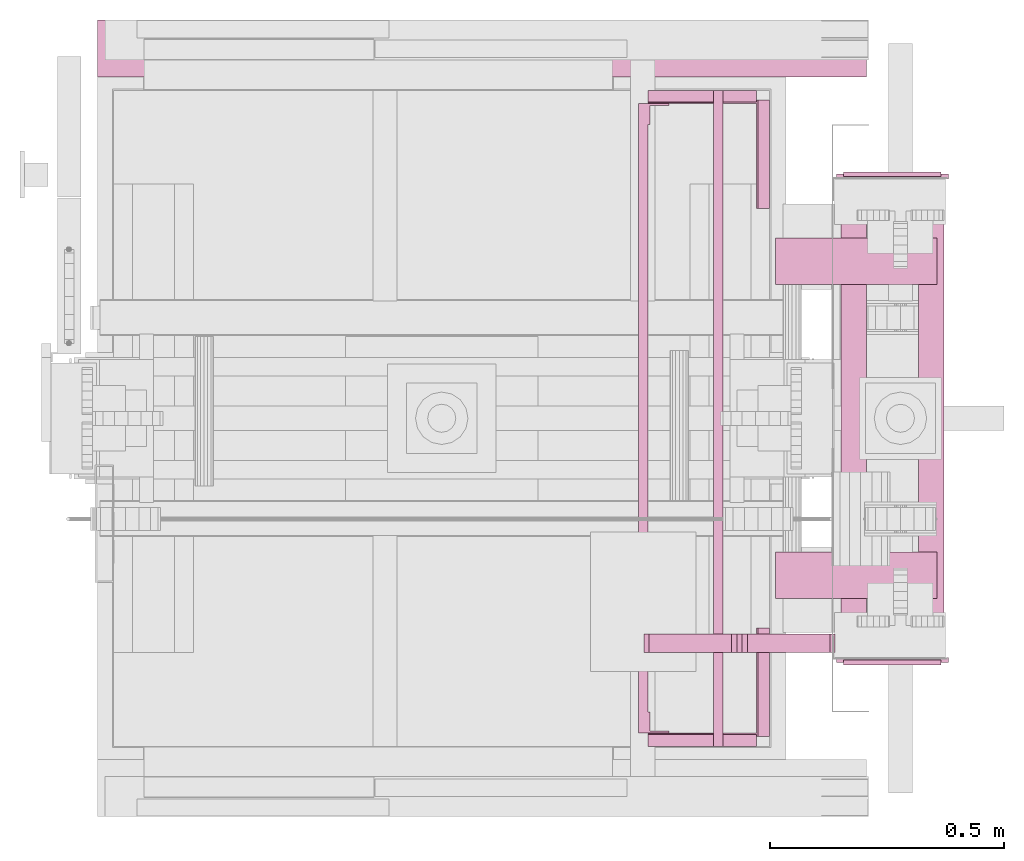
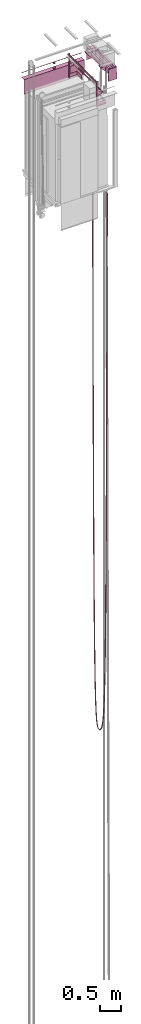
# One storey, part 6 of 13: 4 transport elements.
"""IFC4 building model written with IfcOpenShell, lengths in millimetres."""

from ifc_helpers import new_model, entity, si_unit, converted_unit, frame, origin_with_axes, place, context, subcontext, project, spatial, faceted_brep, element, save


model = new_model("IFC4")

# Units and contexts
context_of_model = context(None, 3, precision=0.01, world=origin_with_axes())
sub_context_1 = subcontext(context_of_model, None, None, "MODEL_VIEW")
sub_context_2 = subcontext(context_of_model, None, None, "MODEL_VIEW")
sub_context_3 = subcontext(context_of_model, None, None, "MODEL_VIEW")
sub_context_4 = subcontext(context_of_model, None, None, "MODEL_VIEW")
ifc_project = project(units=[converted_unit("PLANEANGLEUNIT", "degree", entity("IfcPlaneAngleMeasure", 0.017453292519943), si_unit("PLANEANGLEUNIT", "RADIAN"), dimensions=[0, 0, 0, 0, 0, 0, 0]), si_unit("LENGTHUNIT", "METRE", prefix="MILLI"), si_unit("MASSUNIT", "GRAM", prefix="KILO"), converted_unit("TIMEUNIT", "year", entity("IfcTimeMeasure", 31557600.0), si_unit("TIMEUNIT", "SECOND"), dimensions=[0, 0, 1, 0, 0, 0, 0]), si_unit("THERMODYNAMICTEMPERATUREUNIT", "DEGREE_CELSIUS"), si_unit("AREAUNIT", "SQUARE_METRE"), si_unit("FORCEUNIT", "NEWTON"), si_unit("VOLUMEUNIT", "CUBIC_METRE"), si_unit("PRESSUREUNIT", "PASCAL"), si_unit("SOLIDANGLEUNIT", "STERADIAN")], contexts=[context_of_model])

# Site, building, storey
site = spatial("IfcSite", under=ifc_project)
building = spatial("IfcBuilding", under=site, Name="Document")
placement = place(None, origin_with_axes())
storey_placement = place(placement, frame((0.0, 0.0, -26400.0), z_axis=(0.0, 0.0, 1.0), x_axis=(1.0, 0.0, 0.0)))
storey = spatial("IfcBuildingStorey", under=building, at=storey_placement, Name="Z -26400", Elevation=-26400.0)

# Transport elements
transport_element_1_placement = place(storey_placement, frame((200.0, 325.0, 33569.0), z_axis=(0.0, 0.0, 1.0), x_axis=(1.0, 0.0, 0.0)))
element("IfcTransportElement", 1, at=transport_element_1_placement, inside=storey, PredefinedType="ELEVATOR", context=sub_context_1, shape_type="Brep", body=[
    faceted_brep([(1140.0, 1372.0, 395.0), (1140.0, 1374.0, 395.0), (1140.0, 1374.0, 305.0), (1140.0, 1372.0, 305.0), (1280.0, 1372.0, 395.0), (1280.0, 1372.0, 305.0), (1280.0, 1374.0, 305.0), (1280.0, 1374.0, 395.0)], [[[0, 1, 2, 3]], [[4, 5, 6, 7]], [[0, 3, 5, 4]], [[3, 2, 6, 5]], [[2, 1, 7, 6]], [[1, 0, 4, 7]]]),
    faceted_brep([(1140.0, 1327.0, 700.0), (1140.0, 1372.0, 700.0), (1140.0, 1372.0, 0.0), (1140.0, 1327.0, 0.0), (1145.0, 1367.0, 0.0), (1145.0, 1367.0, 700.0), (1145.0, 1327.0, 700.0), (1145.0, 1327.0, 0.0), (1185.0, 1372.0, 0.0), (1185.0, 1372.0, 700.0), (1185.0, 1367.0, 700.0), (1185.0, 1367.0, 0.0)], [[[0, 1, 2, 3]], [[4, 5, 6, 7]], [[8, 9, 10, 11]], [[7, 6, 0, 3]], [[1, 9, 8, 2]], [[11, 10, 5, 4]], [[2, 8, 11, 4, 7, 3]], [[6, 5, 10, 9, 1, 0]]]),
    faceted_brep([(1140.0, 28.0, 700.0), (1140.0, 73.0, 700.0), (1140.0, 73.0, 0.0), (1140.0, 28.0, 0.0), (1145.0, 73.0, 0.0), (1145.0, 73.0, 700.0), (1145.0, 33.0, 700.0), (1145.0, 33.0, 0.0), (1185.0, 33.0, 0.0), (1185.0, 33.0, 700.0), (1185.0, 28.0, 700.0), (1185.0, 28.0, 0.0)], [[[0, 1, 2, 3]], [[4, 5, 6, 7]], [[8, 9, 10, 11]], [[11, 10, 0, 3]], [[6, 9, 8, 7]], [[1, 5, 4, 2]], [[3, 2, 4, 7, 8, 11]], [[10, 9, 6, 5, 1, 0]]]),
    faceted_brep([(1372.0, 1147.25, 101.0), (1372.0, 1379.25, 101.0), (1372.0, 1379.25, 0.0), (1372.0, 1147.25, 0.0), (1375.0, 1379.25, 3.0), (1375.0, 1379.25, 101.0), (1375.0, 1147.25, 101.0), (1375.0, 1147.25, 3.0), (1400.0, 1379.25, 0.0), (1400.0, 1379.25, 3.0), (1400.0, 1147.25, 3.0), (1400.0, 1147.25, 0.0)], [[[0, 1, 2, 3]], [[4, 5, 6, 7]], [[8, 9, 10, 11]], [[3, 11, 10, 7, 6, 0]], [[1, 5, 4, 9, 8, 2]], [[2, 8, 11, 3]], [[10, 9, 4, 7]], [[6, 5, 1, 0]]]),
    faceted_brep([(1140.0, 26.0, 395.0), (1140.0, 28.0, 395.0), (1140.0, 28.0, 305.0), (1140.0, 26.0, 305.0), (1280.0, 26.0, 395.0), (1280.0, 26.0, 305.0), (1280.0, 28.0, 305.0), (1280.0, 28.0, 395.0)], [[[0, 1, 2, 3]], [[4, 5, 6, 7]], [[0, 3, 5, 4]], [[3, 2, 6, 5]], [[2, 1, 7, 6]], [[1, 0, 4, 7]]]),
    faceted_brep([(1280.0, 0.0, 370.0), (1280.0, 1400.0, 370.0), (1280.0, 1400.0, 330.0), (1280.0, 0.0, 330.0), (1283.0, 1400.0, 333.0), (1283.0, 1400.0, 367.0), (1283.0, 0.0, 367.0), (1283.0, 0.0, 333.0), (1300.0, 1400.0, 330.0), (1300.0, 1400.0, 333.0), (1300.0, 0.0, 333.0), (1300.0, 0.0, 330.0), (1300.0, 1400.0, 367.0), (1300.0, 1400.0, 370.0), (1300.0, 0.0, 370.0), (1300.0, 0.0, 367.0)], [[[0, 1, 2, 3]], [[4, 5, 6, 7]], [[8, 9, 10, 11]], [[12, 13, 14, 15]], [[11, 10, 7, 6, 15, 14, 0, 3]], [[2, 1, 13, 12, 5, 4, 9, 8]], [[2, 8, 11, 3]], [[10, 9, 4, 7]], [[14, 13, 1, 0]], [[5, 12, 15, 6]]]),
    faceted_brep([(1372.0, 20.75, 101.0), (1372.0, 252.75, 101.0), (1372.0, 252.75, 0.0), (1372.0, 20.75, 0.0), (1375.0, 252.75, 3.0), (1375.0, 252.75, 101.0), (1375.0, 20.75, 101.0), (1375.0, 20.75, 3.0), (1400.0, 252.75, 0.0), (1400.0, 252.75, 3.0), (1400.0, 20.75, 3.0), (1400.0, 20.75, 0.0)], [[[0, 1, 2, 3]], [[4, 5, 6, 7]], [[8, 9, 10, 11]], [[3, 11, 10, 7, 6, 0]], [[1, 5, 4, 9, 8, 2]], [[2, 8, 11, 3]], [[10, 9, 4, 7]], [[6, 5, 1, 0]]]),
    faceted_brep([(1140.0, 1372.0, 101.0), (1140.0, 1375.0, 101.0), (1140.0, 1375.0, 3.0), (1140.0, 1400.0, 3.0), (1140.0, 1400.0, 0.0), (1140.0, 1372.0, 0.0), (1372.0, 1372.0, 0.0), (1372.0, 1400.0, 0.0), (1372.0, 1400.0, 3.0), (1372.0, 1375.0, 3.0), (1372.0, 1375.0, 101.0), (1372.0, 1372.0, 101.0)], [[[0, 1, 2, 3, 4, 5]], [[6, 7, 8, 9, 10, 11]], [[6, 11, 0, 5]], [[1, 10, 9, 2]], [[3, 8, 7, 4]], [[4, 7, 6, 5]], [[9, 8, 3, 2]], [[11, 10, 1, 0]]]),
    faceted_brep([(1140.0, 0.0, 3.0), (1140.0, 25.0, 3.0), (1140.0, 25.0, 101.0), (1140.0, 28.0, 101.0), (1140.0, 28.0, 0.0), (1140.0, 0.0, 0.0), (1372.0, 28.0, 0.0), (1372.0, 28.0, 101.0), (1372.0, 25.0, 101.0), (1372.0, 25.0, 3.0), (1372.0, 0.0, 3.0), (1372.0, 0.0, 0.0)], [[[0, 1, 2, 3, 4, 5]], [[6, 7, 8, 9, 10, 11]], [[11, 10, 0, 5]], [[9, 8, 2, 1]], [[3, 7, 6, 4]], [[4, 6, 11, 5]], [[10, 9, 1, 0]], [[8, 7, 3, 2]]]),
    faceted_brep([(1120.0, 28.0, 700.0), (1120.0, 1372.0, 700.0), (1120.0, 1372.0, 660.0), (1120.0, 28.0, 660.0), (1123.0, 1372.0, 663.0), (1123.0, 1372.0, 697.0), (1123.0, 28.0, 697.0), (1123.0, 28.0, 663.0), (1140.0, 1372.0, 660.0), (1140.0, 1372.0, 663.0), (1140.0, 28.0, 663.0), (1140.0, 28.0, 660.0), (1140.0, 1372.0, 697.0), (1140.0, 1372.0, 700.0), (1140.0, 28.0, 700.0), (1140.0, 28.0, 697.0)], [[[0, 1, 2, 3]], [[4, 5, 6, 7]], [[8, 9, 10, 11]], [[12, 13, 14, 15]], [[11, 10, 7, 6, 15, 14, 0, 3]], [[2, 1, 13, 12, 5, 4, 9, 8]], [[2, 8, 11, 3]], [[10, 9, 4, 7]], [[14, 13, 1, 0]], [[5, 12, 15, 6]]]),
])
transport_element_2_placement = place(storey_placement, frame((765.0, 1875.0, 31219.0), z_axis=(0.0, 0.0, 1.0), x_axis=(-1.0, 0.0, 0.0)))
element("IfcTransportElement", 2, at=transport_element_2_placement, inside=storey, PredefinedType="ELEVATOR", context=sub_context_2, shape_type="Brep", body=[
    faceted_brep([(500.0, 119.0, 2426.0), (500.0, 0.0, 2426.0), (500.0, 0.0, 2226.0), (500.0, 6.0, 2226.0), (500.0, 6.0, 2276.0), (500.0, 119.0, 2276.0), (0.0, 6.0, 2276.0), (0.0, 6.0, 2226.0), (0.0, 0.0, 2226.0), (0.0, 0.0, 2426.0), (0.0, 119.0, 2426.0), (0.0, 119.0, 2276.0)], [[[0, 1, 2, 3, 4, 5]], [[6, 7, 8, 9, 10, 11]], [[11, 10, 0, 5]], [[7, 6, 4, 3]], [[1, 9, 8, 2]], [[4, 6, 11, 5]], [[2, 8, 7, 3]], [[10, 9, 1, 0]]]),
    faceted_brep([(600.0, 122.0, 2666.0), (600.0, 0.0, 2666.0), (600.0, 0.0, 2663.0), (600.0, 119.0, 2663.0), (600.0, 119.0, 2246.0), (600.0, 122.0, 2246.0), (-1042.0, 119.0, 2246.0), (-1042.0, 119.0, 2663.0), (-1042.0, 0.0, 2663.0), (-1042.0, 0.0, 2666.0), (-1042.0, 122.0, 2666.0), (-1042.0, 122.0, 2246.0)], [[[0, 1, 2, 3, 4, 5]], [[6, 7, 8, 9, 10, 11]], [[11, 10, 0, 5]], [[3, 7, 6, 4]], [[1, 9, 8, 2]], [[4, 6, 11, 5]], [[10, 9, 1, 0]], [[2, 8, 7, 3]]]),
    faceted_brep([(-220.0, 64.0, 2691.0), (-222.28363037109375, 75.48046875, 2691.0), (-228.78680419921875, 85.21319580078125, 2691.0), (-238.51947021484375, 91.71640014648438, 2691.0), (-250.0, 94.0, 2691.0), (-261.4804992675781, 91.71640014648438, 2691.0), (-271.2132568359375, 85.2132568359375, 2691.0), (-277.7164001464844, 75.48049926757812, 2691.0), (-280.0, 64.0, 2691.0), (-277.7164001464844, 52.519500732421875, 2691.0), (-271.21319580078125, 42.78678894042969, 2691.0), (-261.4804992675781, 36.28361511230469, 2691.0), (-250.0, 34.0, 2691.0), (-238.51947021484375, 36.28361511230469, 2691.0), (-228.78680419921875, 42.78678894042969, 2691.0), (-222.28363037109375, 52.519500732421875, 2691.0), (-220.0, 64.0, 2666.0), (-222.28363037109375, 52.519500732421875, 2666.0), (-228.78680419921875, 42.78678894042969, 2666.0), (-238.51947021484375, 36.28361511230469, 2666.0), (-250.0, 34.0, 2666.0), (-261.4804992675781, 36.28361511230469, 2666.0), (-271.21319580078125, 42.78678894042969, 2666.0), (-277.7164001464844, 52.519500732421875, 2666.0), (-280.0, 64.0, 2666.0), (-277.7164001464844, 75.48049926757812, 2666.0), (-271.2132568359375, 85.2132568359375, 2666.0), (-261.4804992675781, 91.71640014648438, 2666.0), (-250.0, 94.0, 2666.0), (-238.51947021484375, 91.71640014648438, 2666.0), (-228.78680419921875, 85.21319580078125, 2666.0), (-222.28363037109375, 75.48046875, 2666.0)], [[[0, 1, 2, 3, 4, 5, 6, 7, 8, 9, 10, 11, 12, 13, 14, 15]], [[16, 17, 18, 19, 20, 21, 22, 23, 24, 25, 26, 27, 28, 29, 30, 31]], [[0, 15, 17, 16]], [[15, 14, 18, 17]], [[14, 13, 19, 18]], [[13, 12, 20, 19]], [[12, 11, 21, 20]], [[11, 10, 22, 21]], [[10, 9, 23, 22]], [[9, 8, 24, 23]], [[8, 7, 25, 24]], [[7, 6, 26, 25]], [[6, 5, 27, 26]], [[5, 4, 28, 27]], [[4, 3, 29, 28]], [[3, 2, 30, 29]], [[2, 1, 31, 30]], [[1, 0, 16, 31]]]),
    faceted_brep([(0.0, 119.0, 2426.0), (0.0, 0.0, 2426.0), (0.0, 0.0, 2226.0), (0.0, 6.0, 2226.0), (0.0, 6.0, 2276.0), (0.0, 119.0, 2276.0), (-500.0, 6.0, 2276.0), (-500.0, 6.0, 2226.0), (-500.0, 0.0, 2226.0), (-500.0, 0.0, 2426.0), (-500.0, 119.0, 2426.0), (-500.0, 119.0, 2276.0)], [[[0, 1, 2, 3, 4, 5]], [[6, 7, 8, 9, 10, 11]], [[11, 10, 0, 5]], [[7, 6, 4, 3]], [[1, 9, 8, 2]], [[4, 6, 11, 5]], [[2, 8, 7, 3]], [[10, 9, 1, 0]]]),
    faceted_brep([(-220.0, 64.0, 2831.0), (-222.28363037109375, 75.48046875, 2831.0), (-228.78680419921875, 85.21319580078125, 2831.0), (-238.51947021484375, 91.71640014648438, 2831.0), (-250.0, 94.0, 2831.0), (-261.4804992675781, 91.71640014648438, 2831.0), (-271.2132568359375, 85.2132568359375, 2831.0), (-277.7164001464844, 75.48049926757812, 2831.0), (-280.0, 64.0, 2831.0), (-277.7164001464844, 52.519500732421875, 2831.0), (-271.21319580078125, 42.78678894042969, 2831.0), (-261.4804992675781, 36.28361511230469, 2831.0), (-250.0, 34.0, 2831.0), (-238.51947021484375, 36.28361511230469, 2831.0), (-228.78680419921875, 42.78678894042969, 2831.0), (-222.28363037109375, 52.519500732421875, 2831.0), (-220.0, 64.0, 2806.0), (-222.28363037109375, 52.519500732421875, 2806.0), (-228.78680419921875, 42.78678894042969, 2806.0), (-238.51947021484375, 36.28361511230469, 2806.0), (-250.0, 34.0, 2806.0), (-261.4804992675781, 36.28361511230469, 2806.0), (-271.21319580078125, 42.78678894042969, 2806.0), (-277.7164001464844, 52.519500732421875, 2806.0), (-280.0, 64.0, 2806.0), (-277.7164001464844, 75.48049926757812, 2806.0), (-271.2132568359375, 85.2132568359375, 2806.0), (-261.4804992675781, 91.71640014648438, 2806.0), (-250.0, 94.0, 2806.0), (-238.51947021484375, 91.71640014648438, 2806.0), (-228.78680419921875, 85.21319580078125, 2806.0), (-222.28363037109375, 75.48046875, 2806.0)], [[[0, 1, 2, 3, 4, 5, 6, 7, 8, 9, 10, 11, 12, 13, 14, 15]], [[16, 17, 18, 19, 20, 21, 22, 23, 24, 25, 26, 27, 28, 29, 30, 31]], [[0, 15, 17, 16]], [[15, 14, 18, 17]], [[14, 13, 19, 18]], [[13, 12, 20, 19]], [[12, 11, 21, 20]], [[11, 10, 22, 21]], [[10, 9, 23, 22]], [[9, 8, 24, 23]], [[8, 7, 25, 24]], [[7, 6, 26, 25]], [[6, 5, 27, 26]], [[5, 4, 28, 27]], [[4, 3, 29, 28]], [[3, 2, 30, 29]], [[2, 1, 31, 30]], [[1, 0, 16, 31]]]),
    faceted_brep([(600.0, 121.9990234375, 2806.0), (600.0, 0.0, 2806.0), (600.0, 0.0, 2786.0), (600.0, 0.0009765625, 2786.0), (600.0, 0.0009765625, 2806.0), (600.0, 121.9990234375, 2786.0), (600.0, 122.0, 2786.0), (-1042.0, 121.9990234375, 2786.0), (-1042.0, 122.0, 2806.0), (-1042.0, 0.0009765625, 2806.0), (-1042.0, 0.0009765625, 2786.0), (-1042.0, 0.0, 2786.0), (-1042.0, 0.0, 2806.0), (-1042.0, 122.0, 2786.0)], [[[0, 1, 2, 3, 4, 0, 5, 6]], [[7, 8, 9, 10, 11, 12, 8, 13]], [[13, 8, 7, 5, 0, 6]], [[10, 9, 4, 3]], [[1, 12, 11, 2]], [[5, 7, 13, 6]], [[4, 9, 8, 12, 1, 0]], [[2, 11, 10, 3]]]),
])
transport_element_3_placement = place(storey_placement, frame((1794.0, 810.0, 34384.0), z_axis=(0.0, 0.0, 1.0), x_axis=(-1.0, 0.0, 0.0)))
element("IfcTransportElement", 3, at=transport_element_3_placement, inside=storey, PredefinedType="ELEVATOR", context=sub_context_3, shape_type="Brep", body=[
    faceted_brep([(42.0, 94.0, 10.0), (177.0, 94.0, 10.0), (177.0, 94.0, -10.0), (62.0, 94.0, -125.0), (42.0, 94.0, -125.0), (42.0, 86.0, 10.0), (42.0, 86.0, -125.0), (62.0, 86.0, -125.0), (177.0, 86.0, -10.0), (177.0, 86.0, 10.0)], [[[0, 1, 2, 3, 4]], [[5, 6, 7, 8, 9]], [[5, 0, 4, 6]], [[6, 4, 3, 7]], [[7, 3, 2, 8]], [[8, 2, 1, 9]], [[9, 1, 0, 5]]]),
    faceted_brep([(42.00000000000023, -516.0, 10.0), (177.00000000000023, -516.0, 10.0), (177.00000000000023, -516.0, -10.0), (62.00000000000023, -516.0, -125.0), (42.00000000000023, -516.0, -125.0), (42.00000000000023, -524.0, 10.0), (42.00000000000023, -524.0, -125.0), (62.00000000000023, -524.0, -125.0), (177.00000000000023, -524.0, -10.0), (177.00000000000023, -524.0, 10.0)], [[[0, 1, 2, 3, 4]], [[5, 6, 7, 8, 9]], [[5, 0, 4, 6]], [[6, 4, 3, 7]], [[7, 3, 2, 8]], [[8, 2, 1, 9]], [[9, 1, 0, 5]]]),
    faceted_brep([(-123.0, 297.0, -144.0), (-122.99999999999977, -727.0, -144.0), (-122.99999999999977, -727.0, -150.0), (-123.0, 297.0, -150.0), (-172.0, 297.0, 4.0), (-171.99999999999977, -727.0, 4.0), (-171.99999999999977, -727.0, -144.0), (-172.0, 297.0, -144.0), (-177.99999999999977, -727.0, -150.0), (-177.99999999999977, -727.0, 10.0), (-178.0, 297.0, 10.0), (-178.0, 297.0, -150.0), (-123.0, 297.0, 10.0), (-122.99999999999977, -727.0, 10.0), (-122.99999999999977, -727.0, 4.0), (-123.0, 297.0, 4.0)], [[[0, 1, 2, 3]], [[4, 5, 6, 7]], [[8, 9, 10, 11]], [[12, 13, 14, 15]], [[11, 10, 12, 15, 4, 7, 0, 3]], [[1, 6, 5, 14, 13, 9, 8, 2]], [[2, 8, 11, 3]], [[7, 6, 1, 0]], [[14, 5, 4, 15]], [[10, 9, 13, 12]]]),
    faceted_brep([(-163.0, 170.0, 30.0), (-163.0, 70.0, 30.0), (182.0, 70.0, 30.0), (182.0, 170.0, 30.0), (-163.0, 170.0, 10.0), (182.0, 170.0, 10.0), (182.0, 70.0, 10.0), (-163.0, 70.0, 10.0)], [[[0, 1, 2, 3]], [[4, 5, 6, 7]], [[0, 3, 5, 4]], [[3, 2, 6, 5]], [[2, 1, 7, 6]], [[1, 0, 4, 7]]]),
    faceted_brep([(42.0, 297.0, 10.0), (42.00000000000023, -727.0, 10.0), (42.00000000000023, -727.0, -150.0), (42.0, 297.0, -150.0), (36.00000000000023, -727.0, -144.0), (36.00000000000023, -727.0, 4.0), (36.0, 297.0, 4.0), (36.0, 297.0, -144.0), (-12.999999999999773, -727.0, -150.0), (-12.999999999999773, -727.0, -144.0), (-13.0, 297.0, -144.0), (-13.0, 297.0, -150.0), (-12.999999999999773, -727.0, 4.0), (-12.999999999999773, -727.0, 10.0), (-13.0, 297.0, 10.0), (-13.0, 297.0, 4.0)], [[[0, 1, 2, 3]], [[4, 5, 6, 7]], [[8, 9, 10, 11]], [[12, 13, 14, 15]], [[3, 11, 10, 7, 6, 15, 14, 0]], [[1, 13, 12, 5, 4, 9, 8, 2]], [[2, 8, 11, 3]], [[10, 9, 4, 7]], [[14, 13, 1, 0]], [[5, 12, 15, 6]]]),
    faceted_brep([(-162.99999999999977, -500.0, 30.0), (-162.99999999999977, -600.0, 30.0), (182.00000000000023, -600.0, 30.0), (182.00000000000023, -500.0, 30.0), (-162.99999999999977, -500.0, 10.0), (182.00000000000023, -500.0, 10.0), (182.00000000000023, -600.0, 10.0), (-162.99999999999977, -600.0, 10.0)], [[[0, 1, 2, 3]], [[4, 5, 6, 7]], [[0, 3, 5, 4]], [[3, 2, 6, 5]], [[2, 1, 7, 6]], [[1, 0, 4, 7]]]),
    faceted_brep([(36.00000000000023, -741.0, 4.0), (-171.99999999999977, -741.0, 4.0), (-171.99999999999977, -741.0, -144.0), (36.00000000000023, -741.0, -144.0), (36.00000000000023, -731.0, 4.0), (36.00000000000023, -731.0, -144.0), (-171.99999999999977, -731.0, -144.0), (-171.99999999999977, -731.0, 4.0)], [[[0, 1, 2, 3]], [[4, 5, 6, 7]], [[0, 3, 5, 4]], [[3, 2, 6, 5]], [[2, 1, 7, 6]], [[1, 0, 4, 7]]]),
    faceted_brep([(42.0, 154.0, 10.0), (177.0, 154.0, 10.0), (177.0, 154.0, -10.0), (62.0, 154.0, -125.0), (42.0, 154.0, -125.0), (42.0, 146.0, 10.0), (42.0, 146.0, -125.0), (62.0, 146.0, -125.0), (177.0, 146.0, -10.0), (177.0, 146.0, 10.0)], [[[0, 1, 2, 3, 4]], [[5, 6, 7, 8, 9]], [[5, 0, 4, 6]], [[6, 4, 3, 7]], [[7, 3, 2, 8]], [[8, 2, 1, 9]], [[9, 1, 0, 5]]]),
    faceted_brep([(42.00000000000023, -576.0, 10.0), (177.00000000000023, -576.0, 10.0), (177.00000000000023, -576.0, -10.0), (62.00000000000023, -576.0, -125.0), (42.00000000000023, -576.0, -125.0), (42.00000000000023, -584.0, 10.0), (42.00000000000023, -584.0, -125.0), (62.00000000000023, -584.0, -125.0), (177.00000000000023, -584.0, -10.0), (177.00000000000023, -584.0, 10.0)], [[[0, 1, 2, 3, 4]], [[5, 6, 7, 8, 9]], [[5, 0, 4, 6]], [[6, 4, 3, 7]], [[7, 3, 2, 8]], [[8, 2, 1, 9]], [[9, 1, 0, 5]]]),
    faceted_brep([(52.0, 296.0, -150.0), (-188.0, 296.0, -150.0), (-188.0, 296.0, -348.0), (52.0, 296.0, -348.0), (52.0, 306.0, -150.0), (52.0, 306.0, -348.0), (-188.0, 306.0, -348.0), (-188.0, 306.0, -150.0)], [[[0, 1, 2, 3]], [[4, 5, 6, 7]], [[0, 3, 5, 4]], [[3, 2, 6, 5]], [[2, 1, 7, 6]], [[1, 0, 4, 7]]]),
    faceted_brep([(52.00000000000023, -736.0, -150.0), (-187.99999999999977, -736.0, -150.0), (-187.99999999999977, -736.0, -348.0), (52.00000000000023, -736.0, -348.0), (52.00000000000023, -726.0, -150.0), (52.00000000000023, -726.0, -348.0), (-187.99999999999977, -726.0, -348.0), (-187.99999999999977, -726.0, -150.0)], [[[0, 1, 2, 3]], [[4, 5, 6, 7]], [[0, 3, 5, 4]], [[3, 2, 6, 5]], [[2, 1, 7, 6]], [[1, 0, 4, 7]]]),
    faceted_brep([(36.0, 301.0, 4.0), (-172.0, 301.0, 4.0), (-172.0, 301.0, -144.0), (36.0, 301.0, -144.0), (36.0, 311.0, 4.0), (36.0, 311.0, -144.0), (-172.0, 311.0, -144.0), (-172.0, 311.0, 4.0)], [[[0, 1, 2, 3]], [[4, 5, 6, 7]], [[0, 3, 5, 4]], [[3, 2, 6, 5]], [[2, 1, 7, 6]], [[1, 0, 4, 7]]]),
])
transport_element_4_placement = place(storey_placement, frame((1734.0, 545.0, 30820.0), z_axis=(0.0, 0.0, 1.0), x_axis=(0.0, 1.0, 0.0)))
element("IfcTransportElement", 4, at=transport_element_4_placement, inside=storey, ObjectType="Cable", PredefinedType="ELEVATOR", context=sub_context_4, shape_type="Brep", body=[
    faceted_brep([(-20.0, 402.0, 109.98828125), (20.0, 402.0, 109.98828125), (20.0, 388.310302734375, -5837.220703125), (-20.0, 388.310302734375, -5837.220703125), (20.0, 378.3104248046875, -5837.189453125), (20.0, 392.0, 110.01171875), (-20.0, 392.0, 110.01171875), (-20.0, 378.3104248046875, -5837.189453125), (-20.0, 5.0, 0.01171875), (20.0, 5.0, 0.01171875), (20.0, 18.6895751953125, -5905.091796875), (-20.0, 18.6895751953125, -5905.091796875), (20.0, 8.689697265625, -5905.12109375), (20.0, -5.0, -0.01171875), (-20.0, -5.0, -0.01171875), (-20.0, 8.689697265625, -5905.12109375), (20.0, 374.62060546875, -9508.337890625), (-20.0, 374.62060546875, -9508.337890625), (20.0, 364.6207275390625, -9508.2890625), (-20.0, 364.6207275390625, -9508.2890625), (20.0, 32.3792724609375, -9550.203125), (-20.0, 32.3792724609375, -9550.203125), (20.0, 22.37939453125, -9550.251953125), (-20.0, 22.37939453125, -9550.251953125), (20.0, 360.930908203125, -11774.458984375), (-20.0, 360.930908203125, -11774.458984375), (20.0, 350.93115234375, -11774.380859375), (-20.0, 350.93115234375, -11774.380859375), (20.0, 46.06884765625, -11800.251953125), (-20.0, 46.06884765625, -11800.251953125), (20.0, 36.069091796875, -11800.33203125), (-20.0, 36.069091796875, -11800.33203125), (20.0, 347.240966796875, -13173.294921875), (-20.0, 347.240966796875, -13173.294921875), (20.0, 337.2418212890625, -13173.166015625), (-20.0, 337.2418212890625, -13173.166015625), (20.0, 59.7581787109375, -13189.13671875), (-20.0, 59.7581787109375, -13189.13671875), (20.0, 49.759033203125, -13189.265625), (-20.0, 49.759033203125, -13189.265625), (20.0, 333.5506591796875, -14036.763671875), (-20.0, 333.5506591796875, -14036.763671875), (20.0, 323.552734375, -14036.556640625), (-20.0, 323.552734375, -14036.556640625), (20.0, 73.447265625, -14046.4140625), (-20.0, 73.447265625, -14046.4140625), (20.0, 63.4493408203125, -14046.623046875), (-20.0, 63.4493408203125, -14046.623046875), (20.0, 319.859375, -14569.7548828125), (-20.0, 319.859375, -14569.7548828125), (20.0, 309.86474609375, -14569.4189453125), (-20.0, 309.86474609375, -14569.4189453125), (20.0, 87.13525390625, -14575.5009765625), (-20.0, 87.13525390625, -14575.5009765625), (20.0, 77.140625, -14575.83984375), (-20.0, 77.140625, -14575.83984375), (20.0, 306.1654052734375, -14898.736328125), (-20.0, 306.1654052734375, -14898.736328125), (20.0, 296.179443359375, -14898.19140625), (-20.0, 296.179443359375, -14898.19140625), (20.0, 100.8204345703125, -14901.943359375), (-20.0, 100.8204345703125, -14901.943359375), (20.0, 90.834716796875, -14902.4921875), (-20.0, 90.834716796875, -14902.4921875), (20.0, 292.46435546875, -15101.76953125), (-20.0, 292.46435546875, -15101.76953125), (20.0, 282.5010986328125, -15100.888671875), (-20.0, 282.5010986328125, -15100.888671875), (20.0, 114.4986572265625, -15103.2001953125), (-20.0, 114.4986572265625, -15103.2001953125), (20.0, 104.535888671875, -15104.087890625), (-20.0, 104.535888671875, -15104.087890625), (20.0, 278.7449951171875, -15227.03125), (-20.0, 278.7449951171875, -15227.03125), (20.0, 268.8411865234375, -15225.607421875), (-20.0, 268.8411865234375, -15225.607421875), (20.0, 128.158203125, -15227.0263671875), (-20.0, 128.158203125, -15227.0263671875), (20.0, 118.255615234375, -15228.4599609375), (-20.0, 118.255615234375, -15228.4599609375), (20.0, 264.978271484375, -15304.2353515625), (-20.0, 264.978271484375, -15304.2353515625), (20.0, 255.2286376953125, -15301.947265625), (-20.0, 255.2286376953125, -15301.947265625), (20.0, 141.76953125, -15302.810546875), (-20.0, 141.76953125, -15302.810546875), (20.0, 132.0235595703125, -15305.1162109375), (-20.0, 132.0235595703125, -15305.1162109375), (20.0, 251.0914306640625, -15351.6806640625), (-20.0, 251.0914306640625, -15351.6806640625), (20.0, 241.736083984375, -15348.044921875), (-20.0, 241.736083984375, -15348.044921875), (20.0, 155.2593994140625, -15348.5595703125), (-20.0, 155.2593994140625, -15348.5595703125), (20.0, 145.9129638671875, -15352.2197265625), (-20.0, 145.9129638671875, -15352.2197265625), (20.0, 236.9188232421875, -15380.5322265625), (-20.0, 236.9188232421875, -15380.5322265625), (20.0, 228.5294189453125, -15374.9296875), (-20.0, 228.5294189453125, -15374.9296875), (20.0, 168.4599609375, -15375.2197265625), (-20.0, 168.4599609375, -15375.2197265625), (20.0, 160.091796875, -15380.85546875), (-20.0, 160.091796875, -15380.85546875), (20.0, 222.158935546875, -15397.3291015625), (-20.0, 222.158935546875, -15397.3291015625), (-20.0, 215.909912109375, -15389.291015625), (20.0, 215.909912109375, -15389.291015625), (20.0, 181.068115234375, -15389.431640625), (-20.0, 181.068115234375, -15389.431640625), (20.0, 174.8629150390625, -15397.505859375), (-20.0, 174.8629150390625, -15397.505859375), (-20.0, 206.55517578125, -15405.291015625), (-20.0, 190.4786376953125, -15405.3486328125), (-20.0, 192.831787109375, -15395.33984375), (-20.0, 204.134521484375, -15395.298828125), (20.0, 204.134521484375, -15395.298828125), (20.0, 192.831787109375, -15395.33984375), (20.0, 190.4786376953125, -15405.3486328125), (20.0, 206.55517578125, -15405.291015625)], [[[0, 1, 2, 3]], [[4, 5, 6, 7]], [[8, 9, 10, 11]], [[12, 13, 14, 15]], [[3, 2, 16, 17]], [[18, 4, 7, 19]], [[11, 10, 20, 21]], [[22, 12, 15, 23]], [[17, 16, 24, 25]], [[26, 18, 19, 27]], [[21, 20, 28, 29]], [[30, 22, 23, 31]], [[25, 24, 32, 33]], [[34, 26, 27, 35]], [[29, 28, 36, 37]], [[38, 30, 31, 39]], [[33, 32, 40, 41]], [[42, 34, 35, 43]], [[37, 36, 44, 45]], [[46, 38, 39, 47]], [[41, 40, 48, 49]], [[50, 42, 43, 51]], [[45, 44, 52, 53]], [[54, 46, 47, 55]], [[49, 48, 56, 57]], [[58, 50, 51, 59]], [[53, 52, 60, 61]], [[62, 54, 55, 63]], [[57, 56, 64, 65]], [[66, 58, 59, 67]], [[61, 60, 68, 69]], [[70, 62, 63, 71]], [[65, 64, 72, 73]], [[74, 66, 67, 75]], [[69, 68, 76, 77]], [[78, 70, 71, 79]], [[73, 72, 80, 81]], [[82, 74, 75, 83]], [[77, 76, 84, 85]], [[86, 78, 79, 87]], [[81, 80, 88, 89]], [[90, 82, 83, 91]], [[85, 84, 92, 93]], [[94, 86, 87, 95]], [[89, 88, 96, 97]], [[98, 90, 91, 99]], [[93, 92, 100, 101]], [[102, 94, 95, 103]], [[96, 104, 105, 97]], [[106, 107, 98, 99]], [[101, 100, 108, 109]], [[110, 102, 103, 111]], [[105, 112, 113, 111, 103, 95, 87, 79, 71, 63, 55, 47, 39, 31, 23, 15, 14, 8, 11, 21, 29, 37, 45, 53, 61, 69, 77, 85, 93, 101, 109, 114, 115, 106, 99, 91, 83, 75, 67, 59, 51, 43, 35, 27, 19, 7, 6, 0, 3, 17, 25, 33, 41, 49, 57, 65, 73, 81, 89, 97]], [[96, 88, 80, 72, 64, 56, 48, 40, 32, 24, 16, 2, 1, 5, 4, 18, 26, 34, 42, 50, 58, 66, 74, 82, 90, 98, 107, 116, 117, 108, 100, 92, 84, 76, 68, 60, 52, 44, 36, 28, 20, 10, 9, 13, 12, 22, 30, 38, 46, 54, 62, 70, 78, 86, 94, 102, 110, 118, 119, 104]], [[6, 5, 1, 0]], [[119, 118, 113, 112]], [[114, 117, 116, 115]], [[14, 13, 9, 8]], [[104, 119, 112, 105]], [[115, 116, 107, 106]], [[118, 110, 111, 113]], [[109, 108, 117, 114]]]),
])

save(model, "model.ifc")
